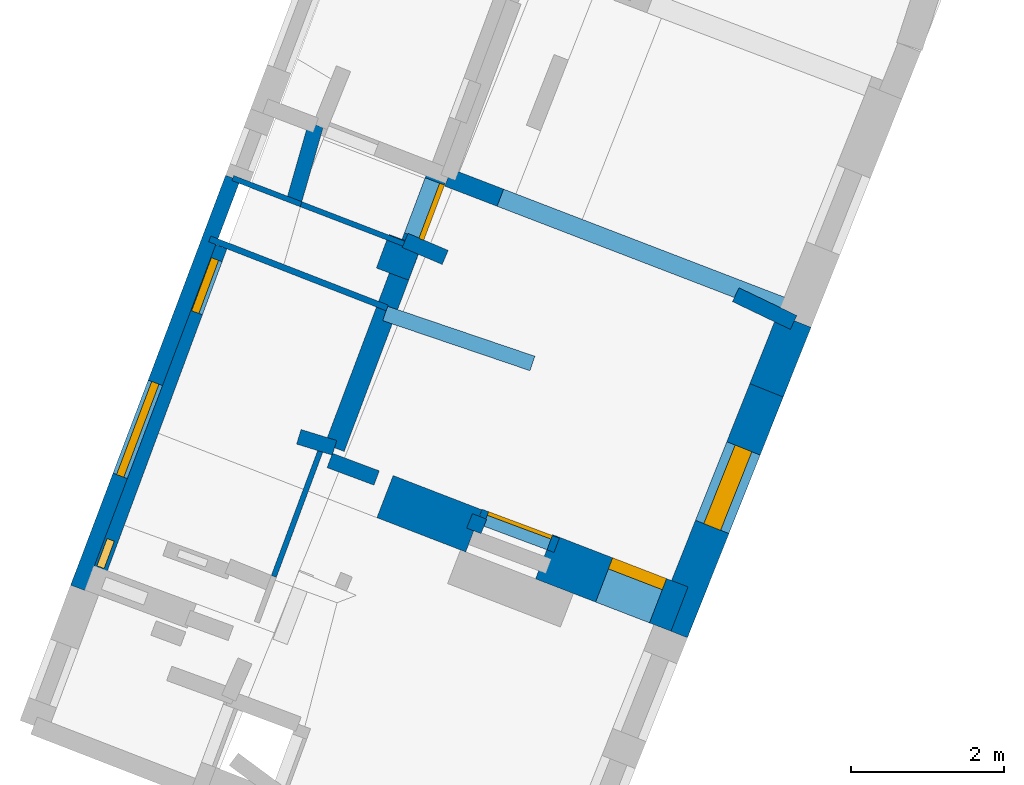
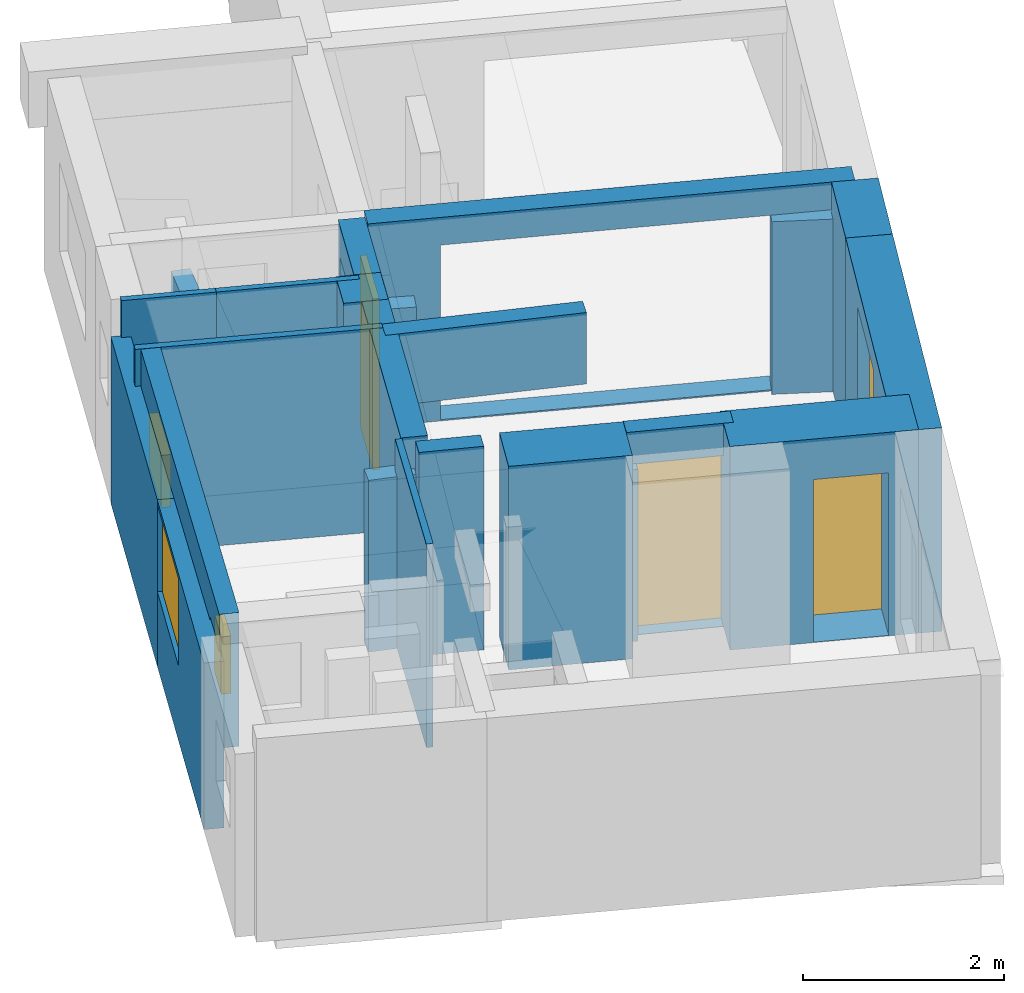
# One storey, part 2 of 5: 23 walls, 4 windows, 3 doors, 8 openings.
"""IFC2X3 building model written with IfcOpenShell, lengths in metres."""

from ifc_helpers import new_model, entity, si_unit, converted_unit, derived_unit, direction, frame, frame_2d, origin, origin_2d_with_axis, place, context, subcontext, project, spatial, polyline, rectangle, outline, extrude, source, transform, mapped, material, layer, layer_set, layer_usage, type_object, type_shapes, element, fill, save


model = new_model("IFC2X3")

# Units and contexts
model_context = context("Model", 3, precision=1e-05, world=origin(), true_north=direction((0.0, 1.0)))
body_context = subcontext(model_context, "Body", "Model", "MODEL_VIEW")
ifc_project = project(units=[si_unit("LENGTHUNIT", "METRE"), si_unit("AREAUNIT", "SQUARE_METRE"), si_unit("VOLUMEUNIT", "CUBIC_METRE"), converted_unit("PLANEANGLEUNIT", "DEGREE", entity("IfcRatioMeasure", 0.0174532925199433), si_unit("PLANEANGLEUNIT", "RADIAN"), dimensions=[0, 0, 0, 0, 0, 0, 0]), si_unit("MASSUNIT", "GRAM", prefix="KILO"), derived_unit("MASSDENSITYUNIT", [(si_unit("MASSUNIT", "GRAM", prefix="KILO"), 1), (si_unit("LENGTHUNIT", "METRE"), -3)]), derived_unit("MOMENTOFINERTIAUNIT", [(si_unit("LENGTHUNIT", "METRE"), 4)]), si_unit("TIMEUNIT", "SECOND"), si_unit("FREQUENCYUNIT", "HERTZ"), si_unit("THERMODYNAMICTEMPERATUREUNIT", "DEGREE_CELSIUS"), derived_unit("THERMALTRANSMITTANCEUNIT", [(si_unit("MASSUNIT", "GRAM", prefix="KILO"), 1), (si_unit("THERMODYNAMICTEMPERATUREUNIT", "KELVIN"), -1), (si_unit("TIMEUNIT", "SECOND"), -3)]), derived_unit("VOLUMETRICFLOWRATEUNIT", [(si_unit("LENGTHUNIT", "METRE"), 3), (si_unit("TIMEUNIT", "SECOND"), -1)]), si_unit("ELECTRICCURRENTUNIT", "AMPERE"), si_unit("ELECTRICVOLTAGEUNIT", "VOLT"), si_unit("POWERUNIT", "WATT"), si_unit("FORCEUNIT", "NEWTON", prefix="KILO"), si_unit("ILLUMINANCEUNIT", "LUX"), si_unit("LUMINOUSFLUXUNIT", "LUMEN"), si_unit("LUMINOUSINTENSITYUNIT", "CANDELA"), derived_unit("USERDEFINED", [(si_unit("MASSUNIT", "GRAM", prefix="KILO"), -1), (si_unit("LENGTHUNIT", "METRE"), -2), (si_unit("TIMEUNIT", "SECOND"), 3), (si_unit("LUMINOUSFLUXUNIT", "LUMEN"), 1)]), derived_unit("LINEARVELOCITYUNIT", [(si_unit("LENGTHUNIT", "METRE"), 1), (si_unit("TIMEUNIT", "SECOND"), -1)]), si_unit("PRESSUREUNIT", "PASCAL"), derived_unit("USERDEFINED", [(si_unit("LENGTHUNIT", "METRE"), -2), (si_unit("MASSUNIT", "GRAM", prefix="KILO"), 1), (si_unit("TIMEUNIT", "SECOND"), -2)]), derived_unit("LINEARFORCEUNIT", [(si_unit("MASSUNIT", "GRAM", prefix="KILO"), 1), (si_unit("LENGTHUNIT", "METRE"), 1), (si_unit("TIMEUNIT", "SECOND"), -2), (si_unit("LENGTHUNIT", "METRE"), -1)]), derived_unit("PLANARFORCEUNIT", [(si_unit("MASSUNIT", "GRAM", prefix="KILO"), 1), (si_unit("LENGTHUNIT", "METRE"), 1), (si_unit("TIMEUNIT", "SECOND"), -2), (si_unit("LENGTHUNIT", "METRE"), -2)])], contexts=[model_context])

# Site, building, storey
placement_1 = place(None, origin())
site = spatial("IfcSite", under=ifc_project, at=placement_1, CompositionType="ELEMENT")
building = spatial("IfcBuilding", under=site, at=placement_1, CompositionType="ELEMENT")
storey_placement = place(placement_1, frame((0.0, 0.0, -81.7791442871094)))
storey = spatial("IfcBuildingStorey", under=building, at=storey_placement, Name="Level 1", CompositionType="ELEMENT", Elevation=-81.7791442871094)

# Walls
ifc_material_1 = material(Name="Default wall")
ifc_layer_1 = layer(ifc_material_1, 0.2)
ifc_layer_set_1 = layer_set([ifc_layer_1], Name="wall_thickness_0.2000")
ifc_layer_usage_1 = layer_usage(ifc_layer_set_1, "AXIS2", "POSITIVE", -0.1)
wall_type_1 = type_object("IfcWallType", Name="wall_thickness_0.2000", PredefinedType="STANDARD", material=ifc_layer_set_1)
wall_1_placement = place(storey_placement, frame((1.71617478759051, 5.45455373589713, 0.0), z_axis=(0.0, 0.0, 1.0), x_axis=(0.901566666279163, -0.432640204158462, 0.0)))
element("IfcWallStandardCase", 1, at=wall_1_placement, inside=storey, type_object=wall_type_1, material=ifc_layer_usage_1, Name="Wall:12", ObjectType="Wall", context=body_context, shape_type="SweptSolid", body=[
    extrude(outline(polyline([(0.838720058835926, -0.1), (0.838720058835926, 0.1), (0.0, 0.1), (0.0, -0.1), (0.838720058835926, -0.1)])), origin(), (0.0, 0.0, 1.0), 2.09180450439453),
])
wall_2_placement = place(storey_placement, frame((-2.6051221785674, 6.16448202782303, 0.0), z_axis=(0.0, 0.0, 1.0), x_axis=(0.920349139810488, -0.391097763800938, 0.0)))
element("IfcWallStandardCase", 2, at=wall_2_placement, inside=storey, type_object=wall_type_1, material=ifc_layer_usage_1, Name="Wall:29", ObjectType="Wall", context=body_context, shape_type="SweptSolid", body=[
    extrude(outline(polyline([(0.570016909705646, -0.1), (0.570016909705646, 0.1), (0.0, 0.1), (0.0, -0.1), (0.570016909705646, -0.1)])), origin(), (0.0, 0.0, 1.0), 2.09180450439453),
])
wall_3_placement = place(storey_placement, frame((-3.99357393562853, 3.59763991622754, 0.0), z_axis=(0.0, 0.0, 1.0), x_axis=(0.955528091857799, -0.29490009438892, 0.0)))
element("IfcWallStandardCase", 3, at=wall_3_placement, inside=storey, type_object=wall_type_1, material=ifc_layer_usage_1, Name="Wall:47", ObjectType="Wall", context=body_context, shape_type="SweptSolid", body=[
    extrude(outline(polyline([(0.488199276311267, -0.1), (0.488199276311267, 0.1), (0.0, 0.1), (0.0, -0.1), (0.488199276311267, -0.1)])), origin(), (0.0, 0.0, 1.0), 2.08080291748047),
])
wall_4_placement = place(storey_placement, frame((-3.58949523128476, 3.28794680020861, 0.0), z_axis=(0.0, 0.0, 1.0), x_axis=(0.936752789751611, -0.349991729748825, 0.0)))
element("IfcWallStandardCase", 4, at=wall_4_placement, inside=storey, type_object=wall_type_1, material=ifc_layer_usage_1, Name="Wall:55", ObjectType="Wall", context=body_context, shape_type="SweptSolid", body=[
    extrude(outline(polyline([(0.653954699615985, -0.1), (0.653954699615985, 0.1), (0.0, 0.1), (0.0, -0.1), (0.653954699615985, -0.1)])), origin(), (0.0, 0.0, 1.0), 2.46645965576172),
])

# Wall, opening, door
wall_5_placement = place(storey_placement, frame((-1.63210361160245, 2.55662165067248, 0.0), z_axis=(0.0, 0.0, 1.0), x_axis=(0.936752722301656, -0.349991910278563, 0.0)))
wall_5 = element("IfcWallStandardCase", 5, at=wall_5_placement, inside=storey, type_object=wall_type_1, material=ifc_layer_usage_1, Name="Wall:56", ObjectType="Wall", context=body_context, shape_type="SweptSolid", body=[
    extrude(outline(polyline([(1.07668912946888, -0.1), (1.07668912946888, 0.1), (0.0, 0.1), (0.0, -0.1), (1.07668912946888, -0.1)])), origin(), (0.0, 0.0, 1.0), 2.46645965576172),
])
opening_1_placement = place(wall_5_placement, frame((0.0891361669663665, -0.1, 0.00579833984375)))
opening_1 = element("IfcOpeningElement", 6, at=opening_1_placement, cuts=wall_5, Name="Opening : 890 x 2070 : 14", ObjectType="Opening", context=body_context, shape_type="SweptSolid", body=[
    extrude(rectangle(XDim=0.89, YDim=2.07, at=frame_2d((1.035, 0.445), x_axis=(0.0, 1.0))), frame((0.0, 0.0, 0.0), z_axis=(0.0, 1.0, 0.0), x_axis=(0.0, 0.0, 1.0)), (0.0, 0.0, 1.0), 0.2),
])
ifc_material_2 = material(Name="Door Panel")
door_style_1 = type_object("IfcDoorStyle", Name="Door : 890 x 2070mm", ConstructionType="NOTDEFINED", OperationType="SINGLE_SWING_RIGHT", ParameterTakesPrecedence=False, Sizeable=False, material=ifc_material_2)
shared_shape_1 = source(origin(), body_context, "Body", "SweptSolid", [
    extrude(rectangle(XDim=0.05, YDim=0.89, at=origin_2d_with_axis()), frame((0.445, 0.175, 0.0), z_axis=(0.0, 0.0, 1.0), x_axis=(0.0, 1.0, 0.0)), (0.0, 0.0, 1.0), 2.07),
])
type_shapes(door_style_1, [shared_shape_1])
door_1_placement = place(opening_1_placement, origin())
door_1 = element("IfcDoor", 7, at=door_1_placement, inside=storey, type_object=door_style_1, Name="Door : 890 x 2070mm : 1", ObjectType="Door : 890 x 2070mm", OverallHeight=2.07, OverallWidth=0.89, context=body_context, shape_type="MappedRepresentation", body=[
    mapped(shared_shape_1, transform((0.0, 0.0, 0.0), scale=1.0)),
])
fill(opening_1, door_1)

# Walls
placement_2 = place(placement_1, frame((0.0, 0.0, -80.177604675293)))
wall_6_placement = place(placement_2, frame((-2.86580187424608, 5.20965326894072, 0.0), z_axis=(0.0, 0.0, 1.0), x_axis=(0.946856586319332, -0.32165603514267, 0.0)))
element("IfcWallStandardCase", 8, at=wall_6_placement, inside=storey, type_object=wall_type_1, material=ifc_layer_usage_1, Name="Wall:64", ObjectType="Wall", context=body_context, shape_type="SweptSolid", body=[
    extrude(outline(polyline([(2.03359189918891, -0.1), (2.03359189918891, 0.1), (0.0, 0.1), (0.0, -0.1), (2.03359189918891, -0.1)])), origin(), (0.0, 0.0, 1.0), 0.864920043945318),
])
wall_7_placement = place(storey_placement, frame((-1.63210369136478, 2.55662127649274, 0.0), z_axis=(0.0, 0.0, 1.0), x_axis=(-0.368127490475387, -0.929775322729257, 0.0)))
element("IfcWallStandardCase", 9, at=wall_7_placement, inside=storey, type_object=wall_type_1, material=ifc_layer_usage_1, Name="Wall:81", ObjectType="Wall", context=body_context, shape_type="SweptSolid", body=[
    extrude(outline(polyline([(0.202810667312004, -0.1), (0.202810667312004, 0.1), (0.0, 0.1), (0.0, -0.1), (0.202810667312004, -0.1)])), origin(), (0.0, 0.0, 1.0), 2.08080291748047),
])
ifc_layer_2 = layer(ifc_material_1, 0.449999988079071)
ifc_layer_set_2 = layer_set([ifc_layer_2], Name="wall_thickness_0.4500")
ifc_layer_usage_2 = layer_usage(ifc_layer_set_2, "AXIS2", "POSITIVE", -0.224999994039536)
wall_type_2 = type_object("IfcWallType", Name="wall_thickness_0.4500", PredefinedType="STANDARD", material=ifc_layer_set_2)
wall_8_placement = place(storey_placement, frame((-2.60512188943674, 6.16448233153238, 0.0), z_axis=(0.0, 0.0, 1.0), x_axis=(-0.350586510477799, -0.936530351174483, 0.0)))
element("IfcWallStandardCase", 10, at=wall_8_placement, inside=storey, type_object=wall_type_2, material=ifc_layer_usage_2, Name="Wall:8", ObjectType="Wall", context=body_context, shape_type="SweptSolid", body=[
    extrude(outline(polyline([(0.470416051991671, -0.224999994039536), (0.470416051991671, 0.224999994039536), (0.0, 0.224999994039536), (0.0, -0.224999994039536), (0.470416051991671, -0.224999994039536)])), origin(), (0.0, 0.0, 1.0), 2.46645965576172),
])
ifc_layer_3 = layer(ifc_material_1, 0.589999973773956)
ifc_layer_set_3 = layer_set([ifc_layer_3], Name="wall_thickness_0.5900")
ifc_layer_usage_3 = layer_usage(ifc_layer_set_3, "AXIS2", "POSITIVE", -0.294999986886978)
wall_type_3 = type_object("IfcWallType", Name="wall_thickness_0.5900", PredefinedType="STANDARD", material=ifc_layer_set_3)
wall_9_placement = place(storey_placement, frame((-2.86708596436096, 2.81590736355303, 0.0), z_axis=(0.0, 0.0, 1.0), x_axis=(0.932920194999935, -0.360083198387934, 0.0)))
element("IfcWallStandardCase", 11, at=wall_9_placement, inside=storey, type_object=wall_type_3, material=ifc_layer_usage_3, Name="Wall:13", ObjectType="Wall", context=body_context, shape_type="SweptSolid", body=[
    extrude(outline(polyline([(1.24375289070802, -0.294999986886978), (1.24375289070802, 0.294999986886978), (0.0, 0.294999986886978), (0.0, -0.294999986886978), (1.24375289070802, -0.294999986886978)])), origin(), (0.0, 0.0, 1.0), 2.46645965576172),
])
ifc_layer_4 = layer(ifc_material_1, 0.469999998807907)
ifc_layer_set_4 = layer_set([ifc_layer_4], Name="wall_thickness_0.4700")
ifc_layer_usage_4 = layer_usage(ifc_layer_set_4, "AXIS2", "POSITIVE", -0.234999999403954)
wall_type_4 = type_object("IfcWallType", Name="wall_thickness_0.4700", PredefinedType="STANDARD", material=ifc_layer_set_4)
wall_10_placement = place(storey_placement, frame((2.48187106160067, 5.11564246466187, 0.0), z_axis=(0.0, 0.0, 1.0), x_axis=(-0.369820426137673, -0.929103251749422, 0.0)))
element("IfcWallStandardCase", 12, at=wall_10_placement, inside=storey, type_object=wall_type_4, material=ifc_layer_usage_4, Name="Wall:22", ObjectType="Wall", context=body_context, shape_type="SweptSolid", body=[
    extrude(outline(polyline([(0.980320082937769, -0.234999999403954), (0.980320082937769, 0.234999999403954), (0.0, 0.234999999403954), (0.0, -0.234999999403954), (0.980320082937769, -0.234999999403954)])), origin(), (0.0, 0.0, 1.0), 2.46645965576172),
])

# Wall, opening, window
wall_11_placement = place(storey_placement, frame((2.11932867077731, 4.20482388784912, 0.0), z_axis=(0.0, 0.0, 1.0), x_axis=(-0.369820361396225, -0.929103277519117, 0.0)))
wall_11 = element("IfcWallStandardCase", 13, at=wall_11_placement, inside=storey, type_object=wall_type_4, material=ifc_layer_usage_4, Name="Wall:23", ObjectType="Wall", context=body_context, shape_type="SweptSolid", body=[
    extrude(outline(polyline([(3.38642309206018, -0.234999999403954), (3.38642309206018, 0.234999999403954), (0.0, 0.234999999403954), (0.0, -0.234999999403954), (3.38642309206018, -0.234999999403954)])), origin(), (0.0, 0.0, 1.0), 2.46645965576172),
])
opening_2_placement = place(wall_11_placement, frame((0.816727645556361, -0.234999999403954, 0.530799865722656)))
opening_2 = element("IfcOpeningElement", 14, at=opening_2_placement, cuts=wall_11, Name="Opening : 1105 x 1660 : 6", ObjectType="Opening", context=body_context, shape_type="SweptSolid", body=[
    extrude(rectangle(XDim=1.105, YDim=1.66, at=frame_2d((0.83, 0.5525), x_axis=(0.0, 1.0))), frame((0.0, 0.0, 0.0), z_axis=(0.0, 1.0, 0.0), x_axis=(0.0, 0.0, 1.0)), (0.0, 0.0, 1.0), 0.469999998807907),
])
ifc_material_3 = material(Name="Window Default")
window_style_1 = type_object("IfcWindowStyle", Name="Window : 1105 x 1660mm", ConstructionType="NOTDEFINED", OperationType="NOTDEFINED", ParameterTakesPrecedence=False, Sizeable=False, material=ifc_material_3)
shared_shape_2 = source(origin(), body_context, "Body", "SweptSolid", [
    extrude(rectangle(XDim=0.234999999403954, YDim=1.105, at=origin_2d_with_axis()), frame((0.5525, 0.234999999403954, 0.0), z_axis=(0.0, 0.0, 1.0), x_axis=(0.0, 1.0, 0.0)), (0.0, 0.0, 1.0), 1.66),
])
type_shapes(window_style_1, [shared_shape_2])
window_1_placement = place(opening_2_placement, origin())
window_1 = element("IfcWindow", 15, at=window_1_placement, inside=storey, type_object=window_style_1, Name="Window : 1105 x 1660mm : 5", ObjectType="Window : 1105 x 1660mm", OverallHeight=1.66, OverallWidth=1.105, context=body_context, shape_type="MappedRepresentation", body=[
    mapped(shared_shape_2, transform((0.0, 0.0, 0.0), scale=1.0)),
])
fill(opening_2, window_1)

# Wall, opening, door
ifc_layer_5 = layer(ifc_material_1, 0.620000004768372)
ifc_layer_set_5 = layer_set([ifc_layer_5], Name="wall_thickness_0.6200")
ifc_layer_usage_5 = layer_usage(ifc_layer_set_5, "AXIS2", "POSITIVE", -0.310000002384186)
wall_type_5 = type_object("IfcWallType", Name="wall_thickness_0.6200", PredefinedType="STANDARD", material=ifc_layer_set_5)
wall_12_placement = place(storey_placement, frame((-0.788292047356034, 2.02962514985492, 0.0), z_axis=(0.0, 0.0, 1.0), x_axis=(0.932920288206127, -0.36008295690493, 0.0)))
wall_12 = element("IfcWallStandardCase", 16, at=wall_12_placement, inside=storey, type_object=wall_type_5, material=ifc_layer_usage_5, Name="Wall:15", ObjectType="Wall", context=body_context, shape_type="SweptSolid", body=[
    extrude(outline(polyline([(1.89715120058669, -0.310000002384186), (1.89715120058669, 0.310000002384186), (0.0, 0.310000002384186), (0.0, -0.310000002384186), (1.89715120058669, -0.310000002384186)])), origin(), (0.0, 0.0, 1.0), 2.46645965576172),
])
opening_3_placement = place(wall_12_placement, frame((0.840979356255182, -0.310000002384186, 0.00579833984375)))
opening_3 = element("IfcOpeningElement", 17, at=opening_3_placement, cuts=wall_12, Name="Opening : 755 x 1970 : 2", ObjectType="Opening", context=body_context, shape_type="SweptSolid", body=[
    extrude(rectangle(XDim=0.755, YDim=1.97, at=frame_2d((0.985, 0.3775), x_axis=(0.0, 1.0))), frame((0.0, 0.0, 0.0), z_axis=(0.0, 1.0, 0.0), x_axis=(0.0, 0.0, 1.0)), (0.0, 0.0, 1.0), 0.620000004768372),
])
door_style_2 = type_object("IfcDoorStyle", Name="Door : 755 x 1970mm", ConstructionType="NOTDEFINED", OperationType="SINGLE_SWING_RIGHT", ParameterTakesPrecedence=False, Sizeable=False, material=ifc_material_2)
shared_shape_3 = source(origin(), body_context, "Body", "SweptSolid", [
    extrude(rectangle(XDim=0.155000001192093, YDim=0.755, at=origin_2d_with_axis()), frame((0.3775, 0.542500004172325, 0.0), z_axis=(0.0, 0.0, 1.0), x_axis=(0.0, 1.0, 0.0)), (0.0, 0.0, 1.0), 1.97),
])
type_shapes(door_style_2, [shared_shape_3])
door_2_placement = place(opening_3_placement, origin())
door_2 = element("IfcDoor", 18, at=door_2_placement, inside=storey, type_object=door_style_2, Name="Door : 755 x 1970mm : 0", ObjectType="Door : 755 x 1970mm", OverallHeight=1.97, OverallWidth=0.755, context=body_context, shape_type="MappedRepresentation", body=[
    mapped(shared_shape_3, transform((0.0, 0.0, 0.0), scale=1.0)),
])
fill(opening_3, door_2)

# Wall
ifc_layer_6 = layer(ifc_material_1, 0.200000002980232)
ifc_layer_set_6 = layer_set([ifc_layer_6], Name="wall_thickness_0.2000")
ifc_layer_usage_6 = layer_usage(ifc_layer_set_6, "AXIS2", "POSITIVE", -0.100000001490116)
wall_type_6 = type_object("IfcWallType", Name="wall_thickness_0.2000", PredefinedType="STANDARD", material=ifc_layer_set_6)
wall_13_placement = place(storey_placement, frame((-4.85670927224523, 6.97910186670137, 0.0), z_axis=(0.0, 0.0, 1.0), x_axis=(-0.353606009816192, -0.935394456805187, 0.0)))
element("IfcWallStandardCase", 19, at=wall_13_placement, inside=storey, type_object=wall_type_6, material=ifc_layer_usage_6, Name="Wall:16", ObjectType="Wall", context=body_context, shape_type="SweptSolid", body=[
    extrude(outline(polyline([(2.86129122098874, -0.100000001490116), (2.86129122098874, 0.100000001490116), (0.0, 0.100000001490116), (0.0, -0.100000001490116), (2.86129122098874, -0.100000001490116)])), origin(), (0.0, 0.0, 1.0), 2.01880645751953),
])

# Wall, opening, window
wall_14_placement = place(storey_placement, frame((-5.86847904382116, 4.30266591928316, 0.0), z_axis=(0.0, 0.0, 1.0), x_axis=(-0.353605959922928, -0.935394475666274, 0.0)))
wall_14 = element("IfcWallStandardCase", 20, at=wall_14_placement, inside=storey, type_object=wall_type_6, material=ifc_layer_usage_6, Name="Wall:17", ObjectType="Wall", context=body_context, shape_type="SweptSolid", body=[
    extrude(outline(polyline([(2.86390501508869, -0.100000001490116), (2.86390501508869, 0.100000001490116), (0.0, 0.100000001490116), (0.0, -0.100000001490116), (2.86390501508869, -0.100000001490116)])), origin(), (0.0, 0.0, 1.0), 2.01880645751953),
])
opening_4_placement = place(wall_14_placement, frame((-1.76938063013721e-07, -0.100000001490116, 0.905059814453125)))
opening_4 = element("IfcOpeningElement", 21, at=opening_4_placement, cuts=wall_14, Name="Opening : 1300 x 1055 : 3", ObjectType="Opening", context=body_context, shape_type="SweptSolid", body=[
    extrude(rectangle(XDim=1.3, YDim=1.055, at=frame_2d((0.5275, 0.65), x_axis=(0.0, 1.0))), frame((0.0, 0.0, 0.0), z_axis=(0.0, 1.0, 0.0), x_axis=(0.0, 0.0, 1.0)), (0.0, 0.0, 1.0), 0.200000002980232),
])
window_style_2 = type_object("IfcWindowStyle", Name="Window : 1300 x 1055mm", ConstructionType="NOTDEFINED", OperationType="NOTDEFINED", ParameterTakesPrecedence=False, Sizeable=False, material=ifc_material_3)
shared_shape_4 = source(origin(), body_context, "Body", "SweptSolid", [
    extrude(rectangle(XDim=0.100000001490116, YDim=1.3, at=origin_2d_with_axis()), frame((0.65, 0.100000001490116, 0.0), z_axis=(0.0, 0.0, 1.0), x_axis=(0.0, 1.0, 0.0)), (0.0, 0.0, 1.0), 1.055),
])
type_shapes(window_style_2, [shared_shape_4])
window_2_placement = place(opening_4_placement, origin())
window_2 = element("IfcWindow", 22, at=window_2_placement, inside=storey, type_object=window_style_2, Name="Window : 1300 x 1055mm : 2", ObjectType="Window : 1300 x 1055mm", OverallHeight=1.055, OverallWidth=1.3, context=body_context, shape_type="MappedRepresentation", body=[
    mapped(shared_shape_4, transform((0.0, 0.0, 0.0), scale=1.0)),
])
fill(opening_4, window_2)

# Wall
wall_15_placement = place(storey_placement, frame((-3.77134188948451, 7.67141790968512, 0.0), z_axis=(0.0, 0.0, 1.0), x_axis=(-0.275571401761198, -0.961280605510882, 0.0)))
element("IfcWallStandardCase", 23, at=wall_15_placement, inside=storey, type_object=wall_type_6, material=ifc_layer_usage_6, Name="Wall:25", ObjectType="Wall", context=body_context, shape_type="SweptSolid", body=[
    extrude(outline(polyline([(1.03919759669364, -0.100000001490116), (1.03919759669364, 0.100000001490116), (0.0, 0.100000001490116), (0.0, -0.100000001490116), (1.03919759669364, -0.100000001490116)])), origin(), (0.0, 0.0, 1.0), 2.01880645751953),
])

# Wall, openings, windows
placement_3 = place(placement_1, frame((0.0, 0.0, -80.9336013793945)))
wall_16_placement = place(placement_3, frame((-5.02716478165871, 6.08855082413675, 0.0), z_axis=(0.0, 0.0, 1.0), x_axis=(-0.348079353084905, -0.93746507345927, 0.0)))
wall_16 = element("IfcWallStandardCase", 24, at=wall_16_placement, inside=storey, type_object=wall_type_6, material=ifc_layer_usage_6, Name="Wall:51", ObjectType="Wall", context=body_context, shape_type="SweptSolid", body=[
    extrude(outline(polyline([(4.65661091072367, -0.100000001490116), (4.65661091072367, 0.100000001490116), (0.0, 0.100000001490116), (0.0, -0.100000001490116), (4.65661091072367, -0.100000001490116)])), origin(), (0.0, 0.0, 1.0), 1.62091674804688),
])
opening_5_placement = place(wall_16_placement, frame((0.179301128836873, -0.100000001490116, 0.326995849609375)))
opening_5 = element("IfcOpeningElement", 25, at=opening_5_placement, cuts=wall_16, Name="Opening : 740 x 635 : 12", ObjectType="Opening", context=body_context, shape_type="SweptSolid", body=[
    extrude(rectangle(XDim=0.74, YDim=0.635, at=frame_2d((0.3175, 0.37), x_axis=(0.0, 1.0))), frame((0.0, 0.0, 0.0), z_axis=(0.0, 1.0, 0.0), x_axis=(0.0, 0.0, 1.0)), (0.0, 0.0, 1.0), 0.200000002980232),
])
opening_6_placement = place(wall_16_placement, frame((4.09430109809715, -0.100000001490116, 0.521995544433594)))
opening_6 = element("IfcOpeningElement", 26, at=opening_6_placement, cuts=wall_16, Name="Opening : 380 x 695 : 13", ObjectType="Opening", context=body_context, shape_type="SweptSolid", body=[
    extrude(rectangle(XDim=0.38, YDim=0.695, at=frame_2d((0.3475, 0.19), x_axis=(0.0, 1.0))), frame((0.0, 0.0, 0.0), z_axis=(0.0, 1.0, 0.0), x_axis=(0.0, 0.0, 1.0)), (0.0, 0.0, 1.0), 0.200000002980232),
])
window_style_3 = type_object("IfcWindowStyle", Name="Window : 740 x 635mm", ConstructionType="NOTDEFINED", OperationType="NOTDEFINED", ParameterTakesPrecedence=False, Sizeable=False, material=ifc_material_3)
shared_shape_5 = source(origin(), body_context, "Body", "SweptSolid", [
    extrude(rectangle(XDim=0.100000001490116, YDim=0.74, at=origin_2d_with_axis()), frame((0.37, 0.100000001490116, 0.0), z_axis=(0.0, 0.0, 1.0), x_axis=(0.0, 1.0, 0.0)), (0.0, 0.0, 1.0), 0.635),
])
type_shapes(window_style_3, [shared_shape_5])
window_3_placement = place(opening_5_placement, origin())
window_3 = element("IfcWindow", 27, at=window_3_placement, inside=storey, type_object=window_style_3, Name="Window : 740 x 635mm : 10", ObjectType="Window : 740 x 635mm", OverallHeight=0.635, OverallWidth=0.74, context=body_context, shape_type="MappedRepresentation", body=[
    mapped(shared_shape_5, transform((0.0, 0.0, 0.0), scale=1.0)),
])
fill(opening_5, window_3)
window_style_4 = type_object("IfcWindowStyle", Name="Window : 380 x 695mm", ConstructionType="NOTDEFINED", OperationType="NOTDEFINED", ParameterTakesPrecedence=False, Sizeable=False, material=ifc_material_3)
shared_shape_6 = source(origin(), body_context, "Body", "SweptSolid", [
    extrude(rectangle(XDim=0.100000001490116, YDim=0.38, at=origin_2d_with_axis()), frame((0.19, 0.100000001490116, 0.0), z_axis=(0.0, 0.0, 1.0), x_axis=(0.0, 1.0, 0.0)), (0.0, 0.0, 1.0), 0.695),
])
type_shapes(window_style_4, [shared_shape_6])
window_4_placement = place(opening_6_placement, origin())
window_4 = element("IfcWindow", 28, at=window_4_placement, inside=storey, type_object=window_style_4, Name="Window : 380 x 695mm : 11", ObjectType="Window : 380 x 695mm", OverallHeight=0.695, OverallWidth=0.38, context=body_context, shape_type="MappedRepresentation", body=[
    mapped(shared_shape_6, transform((0.0, 0.0, 0.0), scale=1.0)),
])
fill(opening_6, window_4)

# Wall, opening
ifc_layer_7 = layer(ifc_material_1, 0.239999994635582)
ifc_layer_set_7 = layer_set([ifc_layer_7], Name="wall_thickness_0.2400")
ifc_layer_usage_7 = layer_usage(ifc_layer_set_7, "AXIS2", "POSITIVE", -0.119999997317791)
wall_type_7 = type_object("IfcWallType", Name="wall_thickness_0.2400", PredefinedType="STANDARD", material=ifc_layer_set_7)
wall_17_placement = place(storey_placement, frame((-2.04320077714251, 6.98493880768696, 0.0), z_axis=(0.0, 0.0, 1.0), x_axis=(0.933322902178305, -0.359038104202695, 0.0)))
wall_17 = element("IfcWallStandardCase", 29, at=wall_17_placement, inside=storey, type_object=wall_type_7, material=ifc_layer_usage_7, Name="Wall:26", ObjectType="Wall", context=body_context, shape_type="SweptSolid", body=[
    extrude(outline(polyline([(4.89589134342495, -0.119999997317791), (4.89589134342495, 0.119999997317791), (0.0, 0.119999997317791), (0.0, -0.119999997317791), (4.89589134342495, -0.119999997317791)])), origin(), (0.0, 0.0, 1.0), 2.46645965576172),
])
opening_7_placement = place(wall_17_placement, frame((0.731904363735229, -0.119999997317791, 0.0158004760742188)))
element("IfcOpeningElement", 30, at=opening_7_placement, cuts=wall_17, Name="Opening : 4200 x 2115 : 9", ObjectType="Opening", context=body_context, shape_type="SweptSolid", body=[
    extrude(rectangle(XDim=4.2, YDim=2.115, at=frame_2d((1.0575, 2.1), x_axis=(0.0, 1.0))), frame((0.0, 0.0, 0.0), z_axis=(0.0, 1.0, 0.0), x_axis=(0.0, 0.0, 1.0)), (0.0, 0.0, 1.0), 0.239999994635582),
])

# Walls
ifc_layer_8 = layer(ifc_material_1, 0.0700000002980232)
ifc_layer_set_8 = layer_set([ifc_layer_8], Name="wall_thickness_0.0700")
ifc_layer_usage_8 = layer_usage(ifc_layer_set_8, "AXIS2", "POSITIVE", -0.0350000001490116)
wall_type_8 = type_object("IfcWallType", Name="wall_thickness_0.0700", PredefinedType="STANDARD", material=ifc_layer_set_8)
wall_18_placement = place(storey_placement, frame((-4.85670935139731, 6.9791012453585, 0.0), z_axis=(0.0, 0.0, 1.0), x_axis=(0.933604420575337, -0.35830543657917, 0.0)))
element("IfcWallStandardCase", 31, at=wall_18_placement, inside=storey, type_object=wall_type_8, material=ifc_layer_usage_8, Name="Wall:41", ObjectType="Wall", context=body_context, shape_type="SweptSolid", body=[
    extrude(outline(polyline([(0.955436480235818, -0.0350000001490116), (0.955436480235818, 0.0350000001490116), (0.0, 0.0350000001490116), (0.0, -0.0350000001490116), (0.955436480235818, -0.0350000001490116)])), origin(), (0.0, 0.0, 1.0), 2.46645965576172),
])
wall_19_placement = place(storey_placement, frame((-3.96470962987021, 6.63676316018394, 0.0), z_axis=(0.0, 0.0, 1.0), x_axis=(0.93360440748678, -0.35830547068285, 0.0)))
element("IfcWallStandardCase", 32, at=wall_19_placement, inside=storey, type_object=wall_type_8, material=ifc_layer_usage_8, Name="Wall:42", ObjectType="Wall", context=body_context, shape_type="SweptSolid", body=[
    extrude(outline(polyline([(1.43892032618756, -0.0350000001490116), (1.43892032618756, 0.0350000001490116), (0.0, 0.0350000001490116), (0.0, -0.0350000001490116), (1.43892032618756, -0.0350000001490116)])), origin(), (0.0, 0.0, 1.0), 2.46645965576172),
])
wall_20_placement = place(storey_placement, frame((-3.67907782502591, 3.50057883783145, 0.0), z_axis=(0.0, 0.0, 1.0), x_axis=(-0.347980923671976, -0.937501614270823, 0.0)))
element("IfcWallStandardCase", 33, at=wall_20_placement, inside=storey, type_object=wall_type_8, material=ifc_layer_usage_8, Name="Wall:74", ObjectType="Wall", context=body_context, shape_type="SweptSolid", body=[
    extrude(outline(polyline([(1.84296633955621, -0.0350000001490116), (1.84296633955621, 0.0350000001490116), (0.0, 0.0350000001490116), (0.0, -0.0350000001490116), (1.84296633955621, -0.0350000001490116)])), origin(), (0.0, 0.0, 1.0), 2.46645965576172),
])
ifc_layer_9 = layer(ifc_material_1, 0.0799999982118607)
ifc_layer_set_9 = layer_set([ifc_layer_9], Name="wall_thickness_0.0800")
ifc_layer_usage_9 = layer_usage(ifc_layer_set_9, "AXIS2", "POSITIVE", -0.0399999991059303)
wall_type_9 = type_object("IfcWallType", Name="wall_thickness_0.0800", PredefinedType="STANDARD", material=ifc_layer_set_9)
wall_21_placement = place(storey_placement, frame((-5.15734856596698, 6.18382152512199, 0.0), z_axis=(0.0, 0.0, 1.0), x_axis=(0.931902915209975, -0.362707811637894, 0.0)))
element("IfcWallStandardCase", 34, at=wall_21_placement, inside=storey, type_object=wall_type_9, material=ifc_layer_usage_9, Name="Wall:46", ObjectType="Wall", context=body_context, shape_type="SweptSolid", body=[
    extrude(outline(polyline([(2.48799383355297, -0.0399999991059303), (2.48799383355297, 0.0399999991059303), (0.0, 0.0399999991059303), (0.0, -0.0399999991059303), (2.48799383355297, -0.0399999991059303)])), origin(), (0.0, 0.0, 1.0), 2.46645965576172),
])

# Wall, opening, door
ifc_layer_10 = layer(ifc_material_1, 0.270000010728836)
ifc_layer_set_10 = layer_set([ifc_layer_10], Name="wall_thickness_0.2700")
ifc_layer_usage_10 = layer_usage(ifc_layer_set_10, "AXIS2", "POSITIVE", -0.135000005364418)
wall_type_10 = type_object("IfcWallType", Name="wall_thickness_0.2700", PredefinedType="STANDARD", material=ifc_layer_set_10)
wall_22_placement = place(storey_placement, frame((-2.17775566418144, 7.03670098636069, 0.0), z_axis=(0.0, 0.0, 1.0), x_axis=(-0.352426862525554, -0.935839359383005, 0.0)))
wall_22 = element("IfcWallStandardCase", 35, at=wall_22_placement, inside=storey, type_object=wall_type_10, material=ifc_layer_usage_10, Name="Wall:69", ObjectType="Wall", context=body_context, shape_type="SweptSolid", body=[
    extrude(outline(polyline([(1.91563385860502, -0.135000005364418), (1.91563385860502, 0.135000005364418), (0.0, 0.135000005364418), (0.0, -0.135000005364418), (1.91563385860502, -0.135000005364418)])), origin(), (0.0, 0.0, 1.0), 2.46645965576172),
])
opening_8_placement = place(wall_22_placement, frame((0.108706889144191, -0.135000005364418, 0.0177993774414062)))
opening_8 = element("IfcOpeningElement", 36, at=opening_8_placement, cuts=wall_22, Name="Opening : 770 x 2070 : 20", ObjectType="Opening", context=body_context, shape_type="SweptSolid", body=[
    extrude(rectangle(XDim=0.77, YDim=2.07, at=frame_2d((1.035, 0.385), x_axis=(0.0, 1.0))), frame((0.0, 0.0, 0.0), z_axis=(0.0, 1.0, 0.0), x_axis=(0.0, 0.0, 1.0)), (0.0, 0.0, 1.0), 0.270000010728836),
])
door_style_3 = type_object("IfcDoorStyle", Name="Door : 770 x 2070mm", ConstructionType="NOTDEFINED", OperationType="SINGLE_SWING_RIGHT", ParameterTakesPrecedence=False, Sizeable=False, material=ifc_material_2)
shared_shape_7 = source(origin(), body_context, "Body", "SweptSolid", [
    extrude(rectangle(XDim=0.067500002682209, YDim=0.77, at=origin_2d_with_axis()), frame((0.385, 0.236250009387732, 0.0), z_axis=(0.0, 0.0, 1.0), x_axis=(0.0, 1.0, 0.0)), (0.0, 0.0, 1.0), 2.07),
])
type_shapes(door_style_3, [shared_shape_7])
door_3_placement = place(opening_8_placement, origin())
door_3 = element("IfcDoor", 37, at=door_3_placement, inside=storey, type_object=door_style_3, Name="Door : 770 x 2070mm : 4", ObjectType="Door : 770 x 2070mm", OverallHeight=2.07, OverallWidth=0.77, context=body_context, shape_type="MappedRepresentation", body=[
    mapped(shared_shape_7, transform((0.0, 0.0, 0.0), scale=1.0)),
])
fill(opening_8, door_3)

# Wall
wall_23_placement = place(storey_placement, frame((-2.85287649471733, 5.24397542331137, 0.0), z_axis=(0.0, 0.0, 1.0), x_axis=(-0.352426903885743, -0.93583934380721, 0.0)))
element("IfcWallStandardCase", 38, at=wall_23_placement, inside=storey, type_object=wall_type_10, material=ifc_layer_usage_10, Name="Wall:70", ObjectType="Wall", context=body_context, shape_type="SweptSolid", body=[
    extrude(outline(polyline([(1.91304803150086, -0.135000005364418), (1.91304803150086, 0.135000005364418), (0.0, 0.135000005364418), (0.0, -0.135000005364418), (1.91304803150086, -0.135000005364418)])), origin(), (0.0, 0.0, 1.0), 2.46645965576172),
])

save(model, "model.ifc")
